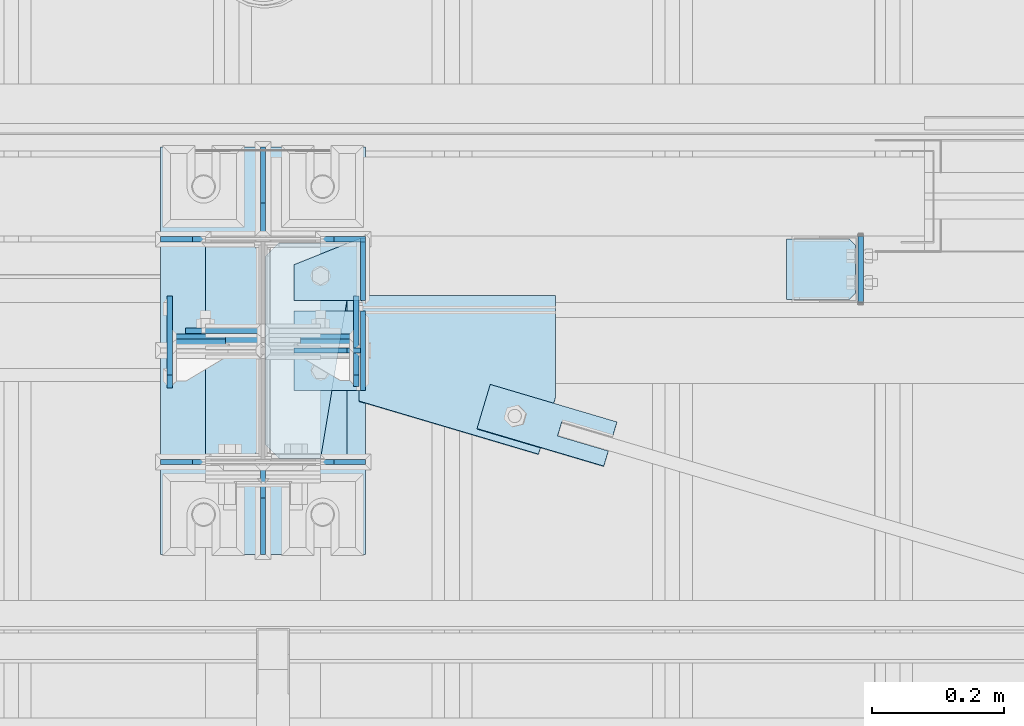
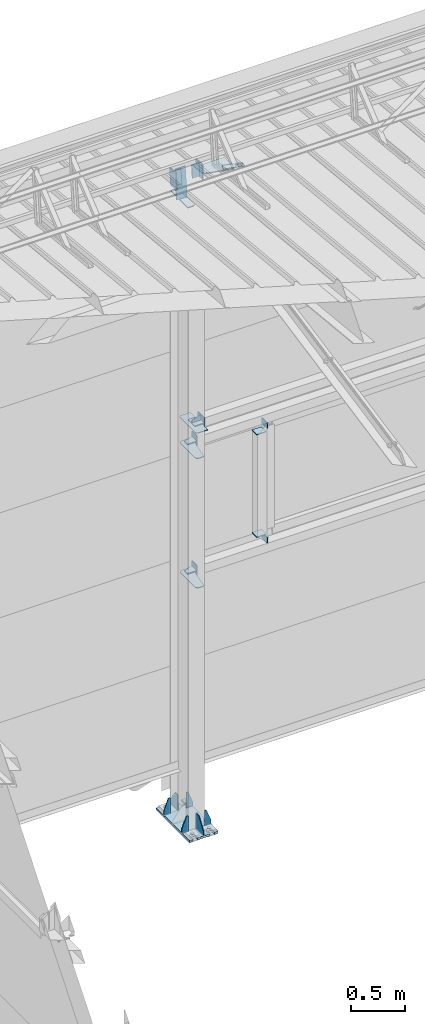
# One storey, part 133 of 709: 29 plates, 5 openings, 8 elements without a shape of their own.
"""IFC4 building model written with IfcOpenShell, lengths in millimetres."""

from ifc_helpers import new_model, si_unit, direction, frame, origin_with_axes, place, context, subcontext, project, spatial, line, arc, indexed_curve, outline, extrude, material, element, aggregate, save


model = new_model("IFC4")

# Units and contexts
model_context = context("Model", 3, precision=0.2, world=origin_with_axes(), true_north=direction((0.0, 1.0)))
body_context = subcontext(model_context, "Body", "Model", "MODEL_VIEW")
ifc_project = project(units=[si_unit("LENGTHUNIT", "METRE", prefix="MILLI"), si_unit("AREAUNIT", "SQUARE_METRE"), si_unit("VOLUMEUNIT", "CUBIC_METRE"), si_unit("MASSUNIT", "GRAM", prefix="KILO"), si_unit("TIMEUNIT", "SECOND"), si_unit("PLANEANGLEUNIT", "RADIAN"), si_unit("SOLIDANGLEUNIT", "STERADIAN"), si_unit("THERMODYNAMICTEMPERATUREUNIT", "DEGREE_CELSIUS"), si_unit("LUMINOUSINTENSITYUNIT", "LUMEN")], contexts=[model_context])

# Site, building, storey
site_placement = place(None, origin_with_axes())
site = spatial("IfcSite", under=ifc_project, at=site_placement, CompositionType="ELEMENT")
building_placement = place(site_placement, origin_with_axes())
building = spatial("IfcBuilding", under=site, at=building_placement, Name="Undefined", CompositionType="ELEMENT")
storey_placement = place(building_placement, origin_with_axes())
storey = spatial("IfcBuildingStorey", under=building, at=storey_placement, Name="Undefined", CompositionType="ELEMENT", Elevation=0.0)

# Assembly, plates, voiding features
assembly_1_placement = place(storey_placement, frame((4000.0, 21827.0, -200.0), z_axis=(-1.0, 0.0, 0.0), x_axis=(0.0, 0.0, 1.0)))
assembly_1 = element("IfcElementAssembly", 1, at=assembly_1_placement, inside=storey)
ifc_material = material(Name="C355-6", Category="STEEL")
plate_1_placement = place(assembly_1_placement, frame((25.0, -168.5, -87.0), z_axis=(0.0, -1.0, 0.0), x_axis=(0.0, 0.0, -1.0)))
plate_1 = element("IfcPlate", 2, at=plate_1_placement, material=ifc_material, ObjectType="419", context=body_context, shape_type="SolidModel", body=[
    extrude(outline(indexed_curve([(0.0, 0.0), (68.0, 0.0), (68.0, 50.0), (20.0, 175.0), (0.0, 175.0)], segments=[line(1, 2, 3, 4, 5, 1)])), frame((0.0, 0.0, 4.0), z_axis=(0.0, 0.0, 1.0), x_axis=(1.0, 0.0, 0.0)), (0.0, 0.0, -1.0), 8.0),
])
plate_2_placement = place(assembly_1_placement, frame((25.0, 168.5, 87.0), z_axis=(0.0, 1.0, 0.0), x_axis=(0.0, 0.0, 1.0)))
plate_2 = element("IfcPlate", 3, at=plate_2_placement, material=ifc_material, ObjectType="419", context=body_context, shape_type="SolidModel", body=[
    extrude(outline(indexed_curve([(0.0, 0.0), (68.0, 0.0), (68.0, 50.0), (20.0, 175.0), (0.0, 175.0)], segments=[line(1, 2, 3, 4, 5, 1)])), frame((0.0, 0.0, 4.0), z_axis=(0.0, 0.0, 1.0), x_axis=(1.0, 0.0, 0.0)), (0.0, 0.0, -1.0), 8.0),
])
plate_3_placement = place(assembly_1_placement, frame((25.0, -168.5, 87.0), z_axis=(0.0, 1.0, 0.0), x_axis=(0.0, 0.0, 1.0)))
plate_3 = element("IfcPlate", 4, at=plate_3_placement, material=ifc_material, ObjectType="419", context=body_context, shape_type="SolidModel", body=[
    extrude(outline(indexed_curve([(0.0, 0.0), (68.0, 0.0), (68.0, 50.0), (20.0, 175.0), (0.0, 175.0)], segments=[line(1, 2, 3, 4, 5, 1)])), frame((0.0, 0.0, 4.0), z_axis=(0.0, 0.0, 1.0), x_axis=(1.0, 0.0, 0.0)), (0.0, 0.0, -1.0), 8.0),
])
plate_4_placement = place(assembly_1_placement, frame((25.0, 168.5, -87.0), z_axis=(0.0, -1.0, 0.0), x_axis=(0.0, 0.0, -1.0)))
plate_4 = element("IfcPlate", 5, at=plate_4_placement, material=ifc_material, ObjectType="419", context=body_context, shape_type="SolidModel", body=[
    extrude(outline(indexed_curve([(0.0, 0.0), (68.0, 0.0), (68.0, 50.0), (20.0, 175.0), (0.0, 175.0)], segments=[line(1, 2, 3, 4, 5, 1)])), frame((0.0, 0.0, 4.0), z_axis=(0.0, 0.0, 1.0), x_axis=(1.0, 0.0, 0.0)), (0.0, 0.0, -1.0), 8.0),
])
plate_5_placement = place(assembly_1_placement, frame((7097.93718, 163.0, 87.0), z_axis=(-1.0, 0.0, 0.0), x_axis=(0.0, 0.0, -1.0)))
plate_5 = element("IfcPlate", 6, at=plate_5_placement, material=ifc_material, ObjectType="461", context=body_context, shape_type="SolidModel", body=[
    extrude(outline(indexed_curve([(0.0, 0.0), (68.0, 0.0), (83.0, 15.0), (83.0, 311.0), (68.0, 326.0), (0.0, 326.0)], segments=[line(1, 2, 3, 4, 5, 6, 1)])), frame((0.0, 0.0, 4.0), z_axis=(0.0, 0.0, 1.0), x_axis=(1.0, 0.0, 0.0)), (0.0, 0.0, -1.0), 8.0),
])
plate_6_placement = place(assembly_1_placement, frame((12.5, -308.0, 155.0), z_axis=(1.0, 0.0, 0.0), x_axis=(0.0, 0.0, -1.0)))
plate_6 = element("IfcPlate", 7, at=plate_6_placement, material=ifc_material, ObjectType="416", context=body_context, shape_type="SolidModel", body=[
    extrude(outline(indexed_curve([(0.0, 0.0), (310.0, 0.0), (310.0, 616.0), (0.0, 616.0)], segments=[line(1, 2, 3, 4, 1)])), frame((0.0, 0.0, 12.5), z_axis=(0.0, 0.0, 1.0), x_axis=(1.0, 0.0, 0.0)), (0.0, 0.0, -1.0), 25.0),
])
voiding_feature_1_placement = place(plate_6_placement, frame((40.0, 616.0, 0.0), z_axis=(0.0, 0.0, -1.0), x_axis=(1.0, 0.0, 0.0)))
element("IfcVoidingFeature", 8, at=voiding_feature_1_placement, cuts=plate_6, PredefinedType="HOLE", context=body_context, shape_type="SolidModel", body=[
    extrude(outline(indexed_curve([(0.0, 0.0), (50.0, 0.0), (50.0, 60.0), (42.67767, 77.67767), (25.0, 85.0), (25.0, 85.0), (7.32233, 77.67767), (0.0, 60.0)], segments=[line(1, 2, 3), arc(3, 4, 5), line(5, 6), arc(6, 7, 8), line(8, 1)])), frame((0.0, 0.0, 12.5), z_axis=(0.0, 0.0, 1.0), x_axis=(1.0, 0.0, 0.0)), (0.0, 0.0, -1.0), 25.0),
])
voiding_feature_2_placement = place(plate_6_placement, frame((40.0, 0.0, 0.0), z_axis=(0.0, 0.0, 1.0), x_axis=(1.0, 0.0, 0.0)))
element("IfcVoidingFeature", 9, at=voiding_feature_2_placement, cuts=plate_6, PredefinedType="HOLE", context=body_context, shape_type="SolidModel", body=[
    extrude(outline(indexed_curve([(0.0, 0.0), (50.0, 0.0), (50.0, 60.0), (42.67767, 77.67767), (25.0, 85.0), (25.0, 85.0), (7.32233, 77.67767), (0.0, 60.0)], segments=[line(1, 2, 3), arc(3, 4, 5), line(5, 6), arc(6, 7, 8), line(8, 1)])), frame((0.0, 0.0, 12.5), z_axis=(0.0, 0.0, 1.0), x_axis=(1.0, 0.0, 0.0)), (0.0, 0.0, -1.0), 25.0),
])
voiding_feature_3_placement = place(plate_6_placement, frame((270.0, 616.0, 0.0), z_axis=(0.0, 0.0, 1.0), x_axis=(-1.0, 0.0, 0.0)))
element("IfcVoidingFeature", 10, at=voiding_feature_3_placement, cuts=plate_6, PredefinedType="HOLE", context=body_context, shape_type="SolidModel", body=[
    extrude(outline(indexed_curve([(0.0, 0.0), (50.0, 0.0), (50.0, 60.0), (42.67767, 77.67767), (25.0, 85.0), (25.0, 85.0), (7.32233, 77.67767), (0.0, 60.0)], segments=[line(1, 2, 3), arc(3, 4, 5), line(5, 6), arc(6, 7, 8), line(8, 1)])), frame((0.0, 0.0, 12.5), z_axis=(0.0, 0.0, 1.0), x_axis=(1.0, 0.0, 0.0)), (0.0, 0.0, -1.0), 25.0),
])
voiding_feature_4_placement = place(plate_6_placement, frame((270.0, 0.0, 0.0), z_axis=(0.0, 0.0, -1.0), x_axis=(-1.0, 0.0, 0.0)))
element("IfcVoidingFeature", 11, at=voiding_feature_4_placement, cuts=plate_6, PredefinedType="HOLE", context=body_context, shape_type="SolidModel", body=[
    extrude(outline(indexed_curve([(0.0, 0.0), (50.0, 0.0), (50.0, 60.0), (42.67767, 77.67767), (25.0, 85.0), (25.0, 85.0), (7.32233, 77.67767), (0.0, 60.0)], segments=[line(1, 2, 3), arc(3, 4, 5), line(5, 6), arc(6, 7, 8), line(8, 1)])), frame((0.0, 0.0, 12.5), z_axis=(0.0, 0.0, 1.0), x_axis=(1.0, 0.0, 0.0)), (0.0, 0.0, -1.0), 25.0),
])
plate_7_placement = place(assembly_1_placement, frame((25.0, 173.0, 0.0), z_axis=(0.0, 0.0, -1.0), x_axis=(0.0, 1.0, 0.0)))
plate_7 = element("IfcPlate", 12, at=plate_7_placement, material=ifc_material, ObjectType="418", context=body_context, shape_type="SolidModel", body=[
    extrude(outline(indexed_curve([(0.0, 0.0), (135.0, 0.0), (135.0, 50.0), (50.0, 175.0), (0.0, 175.0)], segments=[line(1, 2, 3, 4, 5, 1)])), frame((0.0, 0.0, 4.0), z_axis=(0.0, 0.0, 1.0), x_axis=(1.0, 0.0, 0.0)), (0.0, 0.0, -1.0), 8.0),
])
plate_8_placement = place(assembly_1_placement, frame((25.0, -173.0, 0.0), z_axis=(0.0, 0.0, 1.0), x_axis=(0.0, -1.0, 0.0)))
plate_8 = element("IfcPlate", 13, at=plate_8_placement, material=ifc_material, ObjectType="418", context=body_context, shape_type="SolidModel", body=[
    extrude(outline(indexed_curve([(0.0, 0.0), (135.0, 0.0), (135.0, 50.0), (50.0, 175.0), (0.0, 175.0)], segments=[line(1, 2, 3, 4, 5, 1)])), frame((0.0, 0.0, 4.0), z_axis=(0.0, 0.0, 1.0), x_axis=(1.0, 0.0, 0.0)), (0.0, 0.0, -1.0), 8.0),
])
plate_9_placement = place(assembly_1_placement, frame((2742.0, -163.0, -4.0), z_axis=(1.0, 0.0, 0.0), x_axis=(0.0, 0.0, -1.0)))
plate_9 = element("IfcPlate", 14, at=plate_9_placement, material=ifc_material, ObjectType="543", context=body_context, shape_type="SolidModel", body=[
    extrude(outline(indexed_curve([(0.0, 20.0), (20.0, 0.0), (83.0, 0.0), (123.0, 240.0), (123.0, 326.0), (20.0, 326.0), (0.0, 306.0)], segments=[line(1, 2, 3, 4, 5, 6, 7, 1)])), frame((0.0, 0.0, 4.0), z_axis=(0.0, 0.0, 1.0), x_axis=(1.0, 0.0, 0.0)), (0.0, 0.0, -1.0), 8.0),
])
plate_10_placement = place(assembly_1_placement, frame((4212.0, -163.0, -4.0), z_axis=(1.0, 0.0, 0.0), x_axis=(0.0, 0.0, -1.0)))
plate_10 = element("IfcPlate", 15, at=plate_10_placement, material=ifc_material, ObjectType="543", context=body_context, shape_type="SolidModel", body=[
    extrude(outline(indexed_curve([(0.0, 20.0), (20.0, 0.0), (83.0, 0.0), (123.0, 240.0), (123.0, 326.0), (20.0, 326.0), (0.0, 306.0)], segments=[line(1, 2, 3, 4, 5, 6, 7, 1)])), frame((0.0, 0.0, 4.0), z_axis=(0.0, 0.0, 1.0), x_axis=(1.0, 0.0, 0.0)), (0.0, 0.0, -1.0), 8.0),
])
plate_11_placement = place(assembly_1_placement, frame((4502.0, -163.0, -127.0), z_axis=(-1.0, 0.0, 0.0), x_axis=(0.0, 0.0, 1.0)))
plate_11 = element("IfcPlate", 16, at=plate_11_placement, material=ifc_material, ObjectType="547", context=body_context, shape_type="SolidModel", body=[
    extrude(outline(indexed_curve([(0.0, 0.0), (108.0, 0.0), (123.0, 15.0), (123.0, 311.0), (108.0, 326.0), (0.0, 326.0)], segments=[line(1, 2, 3, 4, 5, 6, 1)])), frame((0.0, 0.0, 4.0), z_axis=(0.0, 0.0, 1.0), x_axis=(1.0, 0.0, 0.0)), (0.0, 0.0, -1.0), 8.0),
])
plate_12_placement = place(assembly_1_placement, frame((7434.21506, 30.02921, 3.0), z_axis=(0.099503719, -0.9950371902, 0.0), x_axis=(0.0, 0.0, 1.0)))
plate_12 = element("IfcPlate", 17, at=plate_12_placement, material=ifc_material, ObjectType="581", context=body_context, shape_type="SolidModel", body=[
    extrude(outline(indexed_curve([(0.0, 0.0), (114.0, 0.0), (114.0, 332.53514), (0.0, 332.53514)], segments=[line(1, 2, 3, 4, 1)])), frame((0.0, 0.0, 4.0), z_axis=(0.0, 0.0, 1.0), x_axis=(1.0, 0.0, 0.0)), (0.0, 0.0, -1.0), 8.0),
])
aggregate(assembly_1, [plate_1, plate_2, plate_3, plate_4, plate_5, plate_6, plate_7, plate_8, plate_9, plate_10, plate_11, plate_12])

# Assembly, plates
assembly_2_placement = place(storey_placement, frame((10000.0, 21950.0, 2550.0), z_axis=(0.0, 0.0, -1.0), x_axis=(-1.0, 0.0, 0.0)))
assembly_2 = element("IfcElementAssembly", 18, at=assembly_2_placement, inside=storey)
plate_13_placement = place(assembly_2_placement, frame((5096.0, 50.0, -50.0), z_axis=(-1.0, 0.0, 0.0), x_axis=(0.0, 0.0, -1.0)))
plate_13 = element("IfcPlate", 19, at=plate_13_placement, material=ifc_material, ObjectType="509", context=body_context, shape_type="SolidModel", body=[
    extrude(outline(indexed_curve([(0.0, 0.0), (65.0, 0.0), (65.0, 100.0), (0.0, 100.0)], segments=[line(1, 2, 3, 4, 1)])), frame((0.0, 0.0, 4.0), z_axis=(0.0, 0.0, 1.0), x_axis=(1.0, 0.0, 0.0)), (0.0, 0.0, -1.0), 8.0),
])
plate_14_placement = place(assembly_2_placement, frame((5849.0, 47.0, -60.0), z_axis=(-1.0, 0.0, 0.0), x_axis=(0.0, -1.0, 0.0)))
plate_14 = element("IfcPlate", 20, at=plate_14_placement, material=ifc_material, ObjectType="501", context=body_context, shape_type="SolidModel", body=[
    extrude(outline(indexed_curve([(0.0, 0.0), (94.0, 0.0), (94.0, 120.0), (0.0, 120.0)], segments=[line(1, 2, 3, 4, 1)])), frame((0.0, 0.0, 4.0), z_axis=(0.0, 0.0, 1.0), x_axis=(1.0, 0.0, 0.0)), (0.0, 0.0, -1.0), 8.0),
])
plate_15_placement = place(assembly_2_placement, frame((5853.0, 47.0, 0.0), z_axis=(0.0, 0.0, 1.0), x_axis=(0.0, -1.0, 0.0)))
plate_15 = element("IfcPlate", 21, at=plate_15_placement, material=ifc_material, ObjectType="502", context=body_context, shape_type="SolidModel", body=[
    extrude(outline(indexed_curve([(0.0, 0.0), (94.0, 0.0), (94.0, 100.0), (40.0, 100.0), (0.0, 0.0)], segments=[line(1, 2, 3, 4, 5, 1)])), frame((0.0, 0.0, 4.0), z_axis=(0.0, 0.0, 1.0), x_axis=(1.0, 0.0, 0.0)), (0.0, 0.0, -1.0), 8.0),
])
aggregate(assembly_2, [plate_13, plate_14, plate_15])

assembly_3_placement = place(storey_placement, frame((10000.0, 21950.0, 4020.0), z_axis=(0.0, 0.0, -1.0), x_axis=(-1.0, 0.0, 0.0)))
assembly_3 = element("IfcElementAssembly", 22, at=assembly_3_placement, inside=storey)
plate_16_placement = place(assembly_3_placement, frame((5096.0, -50.0, 50.0), z_axis=(-1.0, 0.0, 0.0), x_axis=(0.0, 0.0, 1.0)))
plate_16 = element("IfcPlate", 23, at=plate_16_placement, material=ifc_material, ObjectType="509", context=body_context, shape_type="SolidModel", body=[
    extrude(outline(indexed_curve([(0.0, 0.0), (65.0, 0.0), (65.0, 100.0), (0.0, 100.0)], segments=[line(1, 2, 3, 4, 1)])), frame((0.0, 0.0, 4.0), z_axis=(0.0, 0.0, 1.0), x_axis=(1.0, 0.0, 0.0)), (0.0, 0.0, -1.0), 8.0),
])
plate_17_placement = place(assembly_3_placement, frame((5853.0, 47.0, 0.0), z_axis=(0.0, 0.0, 1.0), x_axis=(0.0, -1.0, 0.0)))
plate_17 = element("IfcPlate", 24, at=plate_17_placement, material=ifc_material, ObjectType="502", context=body_context, shape_type="SolidModel", body=[
    extrude(outline(indexed_curve([(0.0, 0.0), (94.0, 0.0), (94.0, 100.0), (40.0, 100.0), (0.0, 0.0)], segments=[line(1, 2, 3, 4, 5, 1)])), frame((0.0, 0.0, 4.0), z_axis=(0.0, 0.0, 1.0), x_axis=(1.0, 0.0, 0.0)), (0.0, 0.0, -1.0), 8.0),
])
plate_18_placement = place(assembly_3_placement, frame((5849.0, 47.0, -60.0), z_axis=(-1.0, 0.0, 0.0), x_axis=(0.0, -1.0, 0.0)))
plate_18 = element("IfcPlate", 25, at=plate_18_placement, material=ifc_material, ObjectType="501", context=body_context, shape_type="SolidModel", body=[
    extrude(outline(indexed_curve([(0.0, 0.0), (94.0, 0.0), (94.0, 120.0), (0.0, 120.0)], segments=[line(1, 2, 3, 4, 1)])), frame((0.0, 0.0, 4.0), z_axis=(0.0, 0.0, 1.0), x_axis=(1.0, 0.0, 0.0)), (0.0, 0.0, -1.0), 8.0),
])
aggregate(assembly_3, [plate_16, plate_17, plate_18])

assembly_4_placement = place(storey_placement, frame((4850.0, 21950.0, 2600.0), z_axis=(-1.0, 0.0, 0.0), x_axis=(0.0, 0.0, 1.0)))
assembly_4 = element("IfcElementAssembly", 26, at=assembly_4_placement, inside=storey)
plate_19_placement = place(assembly_4_placement, frame((1267.0, -46.0, -46.0), z_axis=(1.0, 0.0, 0.0), x_axis=(0.0, 1.0, 0.0)))
plate_19 = element("IfcPlate", 27, at=plate_19_placement, material=ifc_material, ObjectType="510", context=body_context, shape_type="SolidModel", body=[
    extrude(outline(indexed_curve([(0.0, 10.0), (10.0, 0.0), (82.0, 0.0), (92.0, 10.0), (92.0, 104.0), (0.0, 104.0)], segments=[line(1, 2, 3, 4, 5, 6, 1)])), frame((0.0, 0.0, 4.0), z_axis=(0.0, 0.0, 1.0), x_axis=(1.0, 0.0, 0.0)), (0.0, 0.0, -1.0), 8.0),
])
plate_20_placement = place(assembly_4_placement, frame((103.0, 46.0, -46.0), z_axis=(-1.0, 0.0, 0.0), x_axis=(0.0, -1.0, 0.0)))
plate_20 = element("IfcPlate", 28, at=plate_20_placement, material=ifc_material, ObjectType="510", context=body_context, shape_type="SolidModel", body=[
    extrude(outline(indexed_curve([(0.0, 10.0), (10.0, 0.0), (82.0, 0.0), (92.0, 10.0), (92.0, 104.0), (0.0, 104.0)], segments=[line(1, 2, 3, 4, 5, 6, 1)])), frame((0.0, 0.0, 4.0), z_axis=(0.0, 0.0, 1.0), x_axis=(1.0, 0.0, 0.0)), (0.0, 0.0, -1.0), 8.0),
])
aggregate(assembly_4, [plate_19, plate_20])

assembly_5_placement = place(storey_placement, frame((10000.0, 21827.0, 4310.0), z_axis=(0.0, 0.0, -1.0), x_axis=(-1.0, 0.0, 0.0)))
assembly_5 = element("IfcElementAssembly", 29, at=assembly_5_placement, inside=storey)
plate_21_placement = place(assembly_5_placement, frame((5953.0, 0.0, -60.0), z_axis=(0.0, -1.0, 0.0), x_axis=(0.0, 0.0, 1.0)))
plate_21 = element("IfcPlate", 30, at=plate_21_placement, material=ifc_material, ObjectType="508", context=body_context, shape_type="SolidModel", body=[
    extrude(outline(indexed_curve([(0.0, 80.0), (36.0, 0.0), (56.0, 0.0), (56.0, 90.0), (46.0, 100.0), (0.0, 100.0)], segments=[line(1, 2, 3, 4, 5, 6, 1)])), frame((0.0, 0.0, 4.0), z_axis=(0.0, 0.0, 1.0), x_axis=(1.0, 0.0, 0.0)), (0.0, 0.0, -1.0), 8.0),
])
plate_22_placement = place(assembly_5_placement, frame((5953.0, -60.0, 0.0), z_axis=(0.0, 0.0, 1.0), x_axis=(0.0, 1.0, 0.0)))
plate_22 = element("IfcPlate", 31, at=plate_22_placement, material=ifc_material, ObjectType="507", context=body_context, shape_type="SolidModel", body=[
    extrude(outline(indexed_curve([(0.0, 0.0), (120.0, 0.0), (120.0, 100.0), (0.0, 100.0)], segments=[line(1, 2, 3, 4, 1)])), frame((0.0, 0.0, 4.0), z_axis=(0.0, 0.0, 1.0), x_axis=(1.0, 0.0, 0.0)), (0.0, 0.0, -1.0), 8.0),
])
plate_23_placement = place(assembly_5_placement, frame((5849.0, -60.0, 60.0), z_axis=(1.0, 0.0, 0.0), x_axis=(0.0, 0.0, -1.0)))
plate_23 = element("IfcPlate", 32, at=plate_23_placement, material=ifc_material, ObjectType="506", context=body_context, shape_type="SolidModel", body=[
    extrude(outline(indexed_curve([(0.0, 0.0), (120.0, 0.0), (120.0, 120.0), (0.0, 120.0)], segments=[line(1, 2, 3, 4, 1)])), frame((0.0, 0.0, 4.0), z_axis=(0.0, 0.0, 1.0), x_axis=(1.0, 0.0, 0.0)), (0.0, 0.0, -1.0), 8.0),
])
aggregate(assembly_5, [plate_21, plate_22, plate_23])

# Assembly, plate, voiding feature
assembly_6_placement = place(storey_placement, frame((4000.0, 21840.84566, 7152.41945), z_axis=(-0.2852311229, -0.9537021177, 0.0953702118), x_axis=(0.9584587662, -0.2838155751, 0.028381558)))
assembly_6 = element("IfcElementAssembly", 33, at=assembly_6_placement, inside=storey)
plate_24_placement = place(assembly_6_placement, frame((348.0251, 0.0, -35.0), z_axis=(0.0, 1.0, 0.0), x_axis=(0.0, 0.0, 1.0)))
plate_24 = element("IfcPlate", 34, at=plate_24_placement, material=ifc_material, ObjectType="574", context=body_context, shape_type="SolidModel", body=[
    extrude(outline(indexed_curve([(0.0, 0.0), (70.0, 0.0), (70.0, 200.0), (0.0, 200.0)], segments=[line(1, 2, 3, 4, 1)])), frame((0.0, 0.0, 4.0), z_axis=(0.0, 0.0, 1.0), x_axis=(1.0, 0.0, 0.0)), (0.0, 0.0, -1.0), 8.0),
])
voiding_feature_5_placement = place(plate_24_placement, frame((24.0, 120.0, 0.0), z_axis=(0.0, 0.0, 1.0), x_axis=(1.0, 0.0, 0.0)))
element("IfcVoidingFeature", 35, at=voiding_feature_5_placement, cuts=plate_24, Name="PLATE", PredefinedType="HOLE", context=body_context, shape_type="SolidModel", body=[
    extrude(outline(indexed_curve([(0.0, 0.0), (22.0, 0.0), (22.0, 85.0), (0.0, 85.0)], segments=[line(1, 2, 3, 4, 1)])), frame((0.0, 0.0, 6.5), z_axis=(0.0, 0.0, 1.0), x_axis=(1.0, 0.0, 0.0)), (0.0, 0.0, -1.0), 13.0),
])
aggregate(assembly_6, [plate_24])

# Assembly, plates
assembly_7_placement = place(storey_placement, frame((4000.0, 21840.04963, 7144.41925), z_axis=(0.0, -0.9950371902, 0.099503719), x_axis=(-1.0, 0.0, 0.0)))
assembly_7 = element("IfcElementAssembly", 36, at=assembly_7_placement, inside=storey)
plate_25_placement = place(assembly_7_placement, frame((57.0, -82.0, 0.0), z_axis=(0.0, 0.0, 1.0), x_axis=(1.0, 0.0, 0.0)))
plate_25 = element("IfcPlate", 37, at=plate_25_placement, material=ifc_material, ObjectType="583", context=body_context, shape_type="SolidModel", body=[
    extrude(outline(indexed_curve([(0.0, 0.0), (80.0, 0.0), (80.0, 164.0), (0.0, 164.0)], segments=[line(1, 2, 3, 4, 1)])), frame((0.0, 0.0, 4.0), z_axis=(0.0, 0.0, 1.0), x_axis=(1.0, 0.0, 0.0)), (0.0, 0.0, -1.0), 8.0),
])
plate_26_placement = place(assembly_7_placement, frame((141.0, -97.0, -60.0), z_axis=(-1.0, 0.0, 0.0), x_axis=(0.0, 0.0, 1.0)))
plate_26 = element("IfcPlate", 38, at=plate_26_placement, material=ifc_material, ObjectType="582", context=body_context, shape_type="SolidModel", body=[
    extrude(outline(indexed_curve([(0.0, 0.0), (120.0, 0.0), (120.0, 194.0), (0.0, 194.0)], segments=[line(1, 2, 3, 4, 1)])), frame((0.0, 0.0, 4.0), z_axis=(0.0, 0.0, 1.0), x_axis=(1.0, 0.0, 0.0)), (0.0, 0.0, -1.0), 8.0),
])
aggregate(assembly_7, [plate_25, plate_26])

assembly_8_placement = place(storey_placement, frame((10000.0, 21841.04467, 7154.40952), z_axis=(0.0, -0.9950371902, 0.099503719), x_axis=(-1.0, 0.0, 0.0)))
assembly_8 = element("IfcElementAssembly", 39, at=assembly_8_placement, inside=storey)
plate_27_placement = place(assembly_8_placement, frame((5943.0, 72.0, 0.0), z_axis=(0.0, 0.0, 1.0), x_axis=(-1.0, 0.0, 0.0)))
plate_27 = element("IfcPlate", 40, at=plate_27_placement, material=ifc_material, ObjectType="597", context=body_context, shape_type="SolidModel", body=[
    extrude(outline(indexed_curve([(0.0, 0.0), (80.0, 0.0), (80.0, 144.0), (0.0, 144.0)], segments=[line(1, 2, 3, 4, 1)])), frame((0.0, 0.0, 4.0), z_axis=(0.0, 0.0, 1.0), x_axis=(1.0, 0.0, 0.0)), (0.0, 0.0, -1.0), 8.0),
])
plate_28_placement = place(assembly_8_placement, frame((5859.0, -87.0, 60.0), z_axis=(1.0, 0.0, 0.0), x_axis=(0.0, 0.0, -1.0)))
plate_28 = element("IfcPlate", 41, at=plate_28_placement, material=ifc_material, ObjectType="596", context=body_context, shape_type="SolidModel", body=[
    extrude(outline(indexed_curve([(0.0, 0.0), (120.0, 0.0), (120.0, 174.0), (0.0, 174.0)], segments=[line(1, 2, 3, 4, 1)])), frame((0.0, 0.0, 4.0), z_axis=(0.0, 0.0, 1.0), x_axis=(1.0, 0.0, 0.0)), (0.0, 0.0, -1.0), 8.0),
])
plate_29_placement = place(assembly_8_placement, frame((5557.75102, 10.0, -70.0), z_axis=(0.0, -1.0, 0.0), x_axis=(1.0, 0.0, 0.0)))
plate_29 = element("IfcPlate", 42, at=plate_29_placement, material=ifc_material, Name="PLATE", ObjectType="575", context=body_context, shape_type="SolidModel", body=[
    extrude(outline(indexed_curve([(0.0, 0.0), (297.24898, 0.0), (297.24898, 160.10144), (25.6708, 240.92135), (0.0, 154.66006)], segments=[line(1, 2, 3, 4, 5, 1)])), frame((0.0, 0.0, 4.0), z_axis=(0.0, 0.0, 1.0), x_axis=(1.0, 0.0, 0.0)), (0.0, 0.0, -1.0), 8.0),
])
aggregate(assembly_8, [plate_27, plate_28, plate_29])

save(model, "model.ifc")
